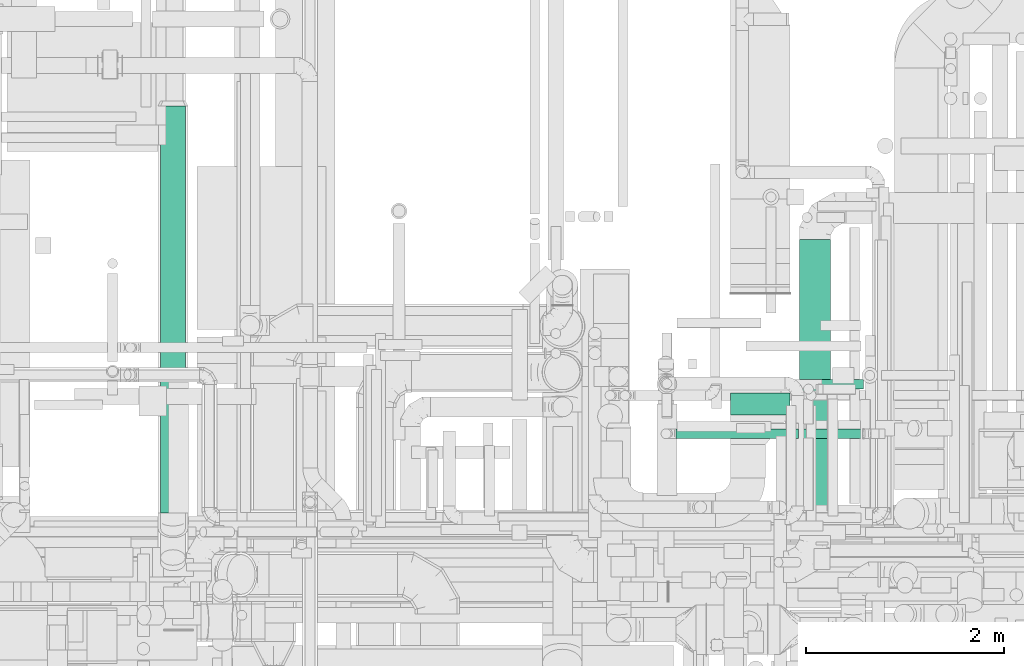
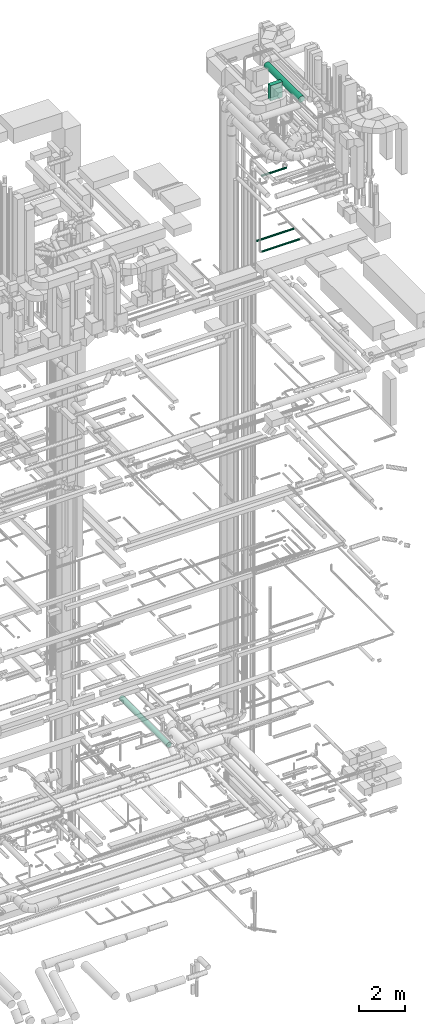
# One storey, part 67 of 337: 6 flow segments.
"""IFC2X3 building model written with IfcOpenShell, lengths in millimetres."""

from ifc_helpers import new_model, entity, si_unit, converted_unit, derived_unit, direction, frame, origin, origin_2d_with_axis, place, context, subcontext, project, spatial, rectangle, circle, extrude, type_object, element, save


model = new_model("IFC2X3")

# Units and contexts
model_context = context("Model", 3, precision=0.01, world=origin(), true_north=direction((6.12303176911189e-17, 1.0)))
body_context = subcontext(model_context, "Body", "Model", "MODEL_VIEW")
ifc_project = project(units=[si_unit("LENGTHUNIT", "METRE", prefix="MILLI"), si_unit("AREAUNIT", "SQUARE_METRE"), si_unit("VOLUMEUNIT", "CUBIC_METRE"), converted_unit("PLANEANGLEUNIT", "DEGREE", entity("IfcRatioMeasure", 0.0174532925199433), si_unit("PLANEANGLEUNIT", "RADIAN"), dimensions=[0, 0, 0, 0, 0, 0, 0]), si_unit("MASSUNIT", "GRAM", prefix="KILO"), derived_unit("MASSDENSITYUNIT", [(si_unit("MASSUNIT", "GRAM", prefix="KILO"), 1), (si_unit("LENGTHUNIT", "METRE"), -3)]), derived_unit("MOMENTOFINERTIAUNIT", [(si_unit("LENGTHUNIT", "METRE"), 4)]), si_unit("TIMEUNIT", "SECOND"), si_unit("FREQUENCYUNIT", "HERTZ"), si_unit("THERMODYNAMICTEMPERATUREUNIT", "DEGREE_CELSIUS"), derived_unit("THERMALTRANSMITTANCEUNIT", [(si_unit("MASSUNIT", "GRAM", prefix="KILO"), 1), (si_unit("THERMODYNAMICTEMPERATUREUNIT", "KELVIN"), -1), (si_unit("TIMEUNIT", "SECOND"), -3)]), derived_unit("VOLUMETRICFLOWRATEUNIT", [(si_unit("LENGTHUNIT", "METRE"), 3), (si_unit("TIMEUNIT", "SECOND"), -1)]), derived_unit("MASSFLOWRATEUNIT", [(si_unit("MASSUNIT", "GRAM", prefix="KILO"), 1), (si_unit("TIMEUNIT", "SECOND"), -1)]), derived_unit("ROTATIONALFREQUENCYUNIT", [(si_unit("TIMEUNIT", "SECOND"), -1)]), si_unit("ELECTRICCURRENTUNIT", "AMPERE"), si_unit("ELECTRICVOLTAGEUNIT", "VOLT"), si_unit("POWERUNIT", "WATT"), si_unit("FORCEUNIT", "NEWTON", prefix="KILO"), si_unit("ILLUMINANCEUNIT", "LUX"), si_unit("LUMINOUSFLUXUNIT", "LUMEN"), si_unit("LUMINOUSINTENSITYUNIT", "CANDELA"), derived_unit("USERDEFINED", [(si_unit("MASSUNIT", "GRAM", prefix="KILO"), -1), (si_unit("LENGTHUNIT", "METRE"), -2), (si_unit("TIMEUNIT", "SECOND"), 3), (si_unit("LUMINOUSFLUXUNIT", "LUMEN"), 1)]), derived_unit("LINEARVELOCITYUNIT", [(si_unit("LENGTHUNIT", "METRE"), 1), (si_unit("TIMEUNIT", "SECOND"), -1)]), si_unit("PRESSUREUNIT", "PASCAL"), derived_unit("USERDEFINED", [(si_unit("LENGTHUNIT", "METRE"), -2), (si_unit("MASSUNIT", "GRAM", prefix="KILO"), 1), (si_unit("TIMEUNIT", "SECOND"), -2)]), derived_unit("LINEARFORCEUNIT", [(si_unit("MASSUNIT", "GRAM", prefix="KILO"), 1), (si_unit("LENGTHUNIT", "METRE"), 1), (si_unit("TIMEUNIT", "SECOND"), -2), (si_unit("LENGTHUNIT", "METRE"), -1)]), derived_unit("PLANARFORCEUNIT", [(si_unit("MASSUNIT", "GRAM", prefix="KILO"), 1), (si_unit("LENGTHUNIT", "METRE"), 1), (si_unit("TIMEUNIT", "SECOND"), -2), (si_unit("LENGTHUNIT", "METRE"), -2)])], contexts=[model_context])

# Site, building, storey
site_placement = place(None, origin())
site = spatial("IfcSite", under=ifc_project, at=site_placement, CompositionType="ELEMENT")
building_placement = place(site_placement, origin())
building = spatial("IfcBuilding", under=site, at=building_placement, CompositionType="ELEMENT")
storey_placement = place(building_placement, origin())
storey = spatial("IfcBuildingStorey", under=building, at=storey_placement, CompositionType="ELEMENT", Elevation=0.0)

# Flow segments
duct_segment_type_1 = type_object("IfcDuctSegmentType", PredefinedType="NOTDEFINED")
flow_segment_1_placement = place(storey_placement, frame((69255.37, 11358.52, 34980.0)))
element("IfcFlowSegment", 1, at=flow_segment_1_placement, inside=storey, type_object=duct_segment_type_1, context=body_context, shape_type="SweptSolid", body=[
    extrude(rectangle(XDim=220.000000000056, YDim=600.000000000002, at=origin_2d_with_axis()), frame((300.0, 110.0, 0.0), z_axis=(0.0, 0.0, 1.0), x_axis=(0.0, -1.0, 0.0)), (0.0, 0.0, 1.0), 800.0),
])
duct_segment_type_2 = type_object("IfcDuctSegmentType", PredefinedType="NOTDEFINED")
flow_segment_2_placement = place(storey_placement, frame((63508.85, 10372.07, 3473.4)))
element("IfcFlowSegment", 2, at=flow_segment_2_placement, inside=storey, type_object=duct_segment_type_2, context=body_context, shape_type="SweptSolid", body=[
    extrude(circle(Radius=125.0, at=origin_2d_with_axis()), frame((126.6, 0.0, 126.6), z_axis=(0.0, 1.0, 0.0), x_axis=(-1.0, 0.0, 0.0)), (0.0, 0.0, 1.0), 4100.63203062379),
])
flow_segment_3_placement = place(storey_placement, frame((69947.16, 10142.35, 35360.9)))
element("IfcFlowSegment", 3, at=flow_segment_3_placement, inside=storey, type_object=duct_segment_type_2, context=body_context, shape_type="SweptSolid", body=[
    extrude(circle(Radius=157.5, at=origin_2d_with_axis()), frame((159.1, 0.0, 159.1), z_axis=(0.0, 1.0, 0.0), x_axis=(1.0, 0.0, 0.0)), (0.0, 0.0, 1.0), 2986.21805226334),
])
flow_segment_4_placement = place(storey_placement, frame((68705.54, 11116.95, 27298.4)))
element("IfcFlowSegment", 4, at=flow_segment_4_placement, inside=storey, type_object=duct_segment_type_2, context=body_context, shape_type="SweptSolid", body=[
    extrude(circle(Radius=50.0, at=origin_2d_with_axis()), frame((0.0, 51.6, 51.6), z_axis=(1.0, 0.0, 0.0), x_axis=(0.0, -1.0, 0.0)), (0.0, 0.0, 1.0), 1881.08165661837),
])
flow_segment_5_placement = place(storey_placement, frame((68733.63, 11615.98, 27548.4)))
element("IfcFlowSegment", 5, at=flow_segment_5_placement, inside=storey, type_object=duct_segment_type_2, context=body_context, shape_type="SweptSolid", body=[
    extrude(circle(Radius=50.0, at=origin_2d_with_axis()), frame((0.0, 51.6, 51.6), z_axis=(1.0, 0.0, 0.0), x_axis=(0.0, -1.0, 0.0)), (0.0, 0.0, 1.0), 1861.25000000002),
])
flow_segment_6_placement = place(storey_placement, frame((68705.54, 11116.95, 31298.4)))
element("IfcFlowSegment", 6, at=flow_segment_6_placement, inside=storey, type_object=duct_segment_type_2, context=body_context, shape_type="SweptSolid", body=[
    extrude(circle(Radius=50.0, at=origin_2d_with_axis()), frame((0.0, 51.6, 51.6), z_axis=(1.0, 0.0, 0.0), x_axis=(0.0, -1.0, 0.0)), (0.0, 0.0, 1.0), 1234.9999999999),
])

save(model, "model.ifc")
